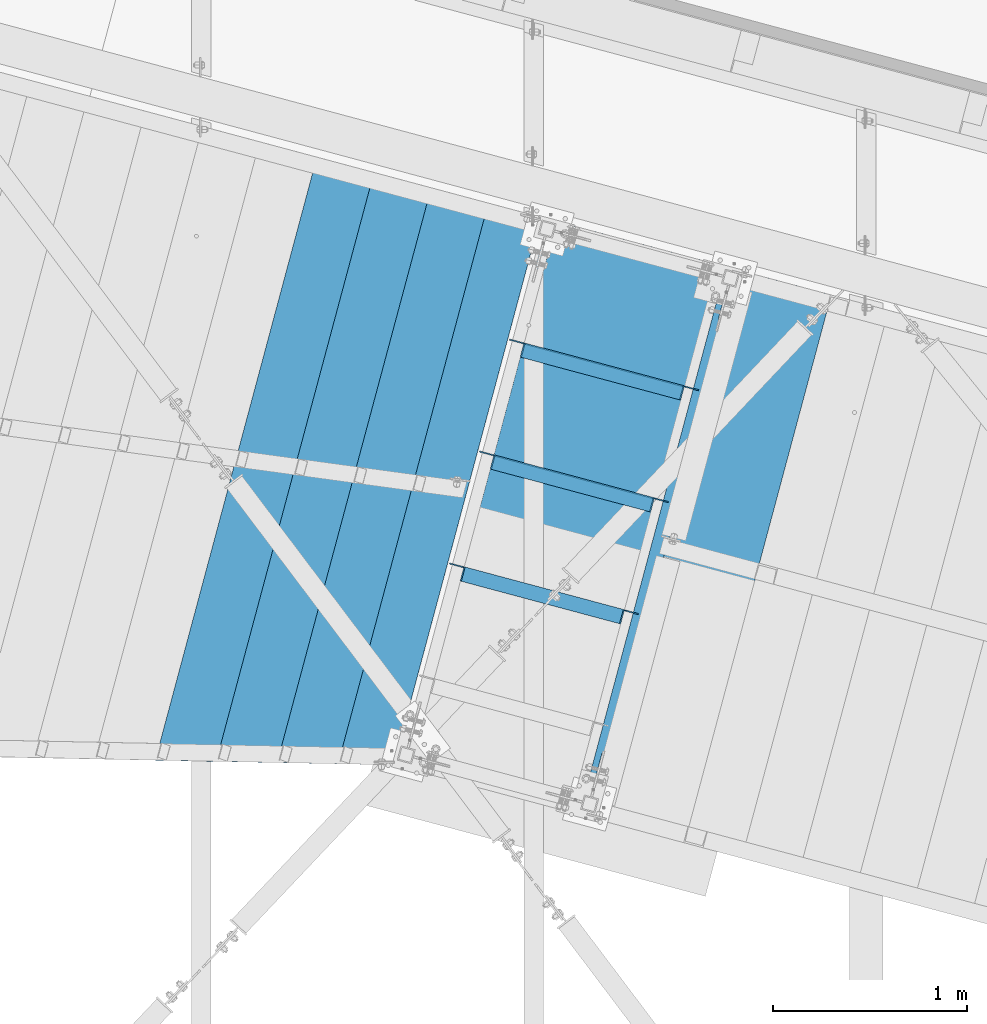
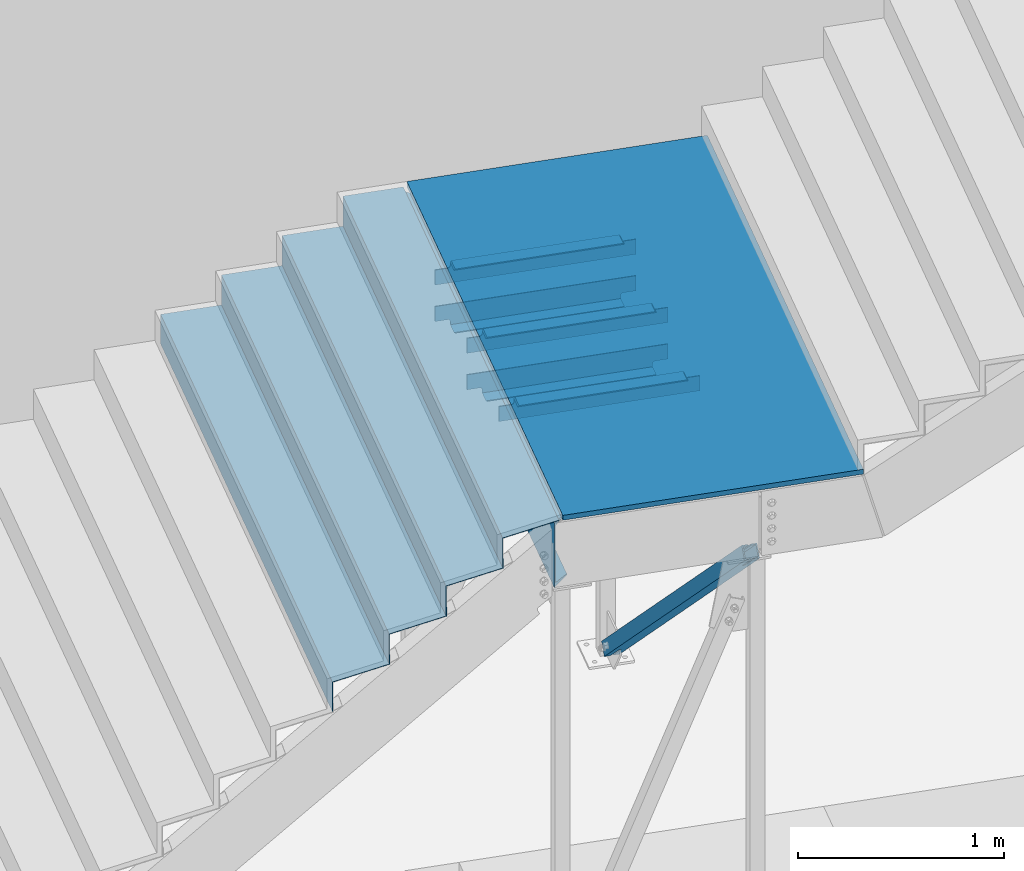
# One storey, part 1173 of 1763: 11 beams, 1 member, 4 elements without a shape of their own.
"""IFC2X3 building model written with IfcOpenShell, lengths in millimetres."""

import ifcopenshell
import ifcopenshell.guid

model = None  # the IFC model being written
_history = None  # IfcOwnerHistory: only IFC2X3 demands one
_inside = {}  # id of a spatial element -> (the spatial element, [elements in it])
_under = {}  # id of a project, library or spatial element -> (it, [spatial elements below it])
_declared = {}  # id of a project -> (the project, [libraries it declares])
_typed = {}  # id of a type object -> (the type object, [elements of that type])
_made_of = {}  # id of a material, layer set ... -> (it, [elements and type objects made of it])


def new_model(schema):
    """Start an empty IFC model of exactly this schema.

    Asked for "IFC4X3", IfcOpenShell would pick the latest addendum, in which some entities
    have other attributes; the version numbers below select the first issue.
    IFC2X3 requires an IfcOwnerHistory on every rooted entity: one is made here for all.
    """
    global model, _history
    if schema == "IFC4X3":
        model = ifcopenshell.file(schema_version=(4, 3, 0, 0))
    else:
        model = ifcopenshell.file(schema=schema)
    _inside.clear()
    _under.clear()
    _declared.clear()
    _typed.clear()
    _made_of.clear()
    _history = None
    if model.schema == "IFC2X3":
        org = make("IfcOrganization", Name="unknown")
        user = make(
            "IfcPersonAndOrganization",
            ThePerson=make("IfcPerson", FamilyName="unknown"),
            TheOrganization=org,
        )
        app = make(
            "IfcApplication",
            ApplicationDeveloper=org,
            Version="unknown",
            ApplicationFullName="unknown",
            ApplicationIdentifier="unknown",
        )
        _history = make(
            "IfcOwnerHistory",
            OwningUser=user,
            OwningApplication=app,
            ChangeAction="ADDED",
            CreationDate=0,
        )
    return model


def make(cls, **values):
    """One entity of the class cls with the attributes given. An attribute that is None is left unset."""
    return model.create_entity(
        cls, **{name: value for name, value in values.items() if value is not None}
    )


def rooted(cls, **values):
    """An entity with a GlobalId (a new one), such as an element, a storey or a relation."""
    return make(cls, GlobalId=ifcopenshell.guid.new(), OwnerHistory=_history, **values)


def si_unit(unit_type, name, prefix=None):
    """IfcSIUnit, for example si_unit("LENGTHUNIT", "METRE", prefix="MILLI")."""
    return make("IfcSIUnit", UnitType=unit_type, Prefix=prefix, Name=name)


def assignment(units):
    """IfcUnitAssignment: the units of a project."""
    return None if units is None else make("IfcUnitAssignment", Units=units)


def point(xyz):
    """IfcCartesianPoint."""
    return None if xyz is None else make("IfcCartesianPoint", Coordinates=xyz)


def direction(xyz):
    """IfcDirection."""
    return None if xyz is None else make("IfcDirection", DirectionRatios=xyz)


def frame(location, z_axis=None, x_axis=None):
    """IfcAxis2Placement3D, a coordinate frame: its origin and axes. An axis left out is left unset."""
    return make(
        "IfcAxis2Placement3D",
        Location=point(location),
        Axis=direction(z_axis),
        RefDirection=direction(x_axis),
    )


def origin_with_axes():
    """The frame at (0, 0, 0) with the z axis (0, 0, 1) and the x axis (1, 0, 0) written out."""
    return frame((0.0, 0.0, 0.0), z_axis=(0.0, 0.0, 1.0), x_axis=(1.0, 0.0, 0.0))


def place(relative_to, where):
    """IfcLocalPlacement: puts the frame where relative to a parent placement (None: the world)."""
    return make(
        "IfcLocalPlacement", PlacementRelTo=relative_to, RelativePlacement=where
    )


def context(
    kind, dimensions, precision=None, world=None, true_north=None, identifier=None
):
    """IfcGeometricRepresentationContext, for example the 3D "Model" context."""
    return make(
        "IfcGeometricRepresentationContext",
        ContextIdentifier=identifier,
        ContextType=kind,
        CoordinateSpaceDimension=dimensions,
        Precision=precision,
        WorldCoordinateSystem=world,
        TrueNorth=true_north,
    )


def subcontext(parent, identifier, kind, view, scale=None):
    """IfcGeometricRepresentationSubContext, for example "Body" below "Model"."""
    return make(
        "IfcGeometricRepresentationSubContext",
        ContextIdentifier=identifier,
        ContextType=kind,
        ParentContext=parent,
        TargetScale=scale,
        TargetView=view,
    )


def project(units=None, contexts=None):
    """IfcProject with its units and contexts."""
    return rooted(
        "IfcProject",
        Name="project",
        RepresentationContexts=contexts,
        UnitsInContext=assignment(units),
    )


def spatial(cls, under=None, at=None, **own):
    """A site, building, storey or space (cls), placed at a placement, below another one or the project."""
    s = rooted(cls, ObjectPlacement=at, **own)
    if under is not None:
        _under.setdefault(under.id(), (under, []))[1].append(s)
    return s


def faces_of(points, faces, orient=None, outer=None):
    """IfcFace entities. A face is a list of loops; a loop is a list of indices into points, from 0.

    orient and outer hold one flag for each loop. By default every Orientation is true, the
    first loop of a face is its IfcFaceOuterBound and the others are IfcFaceBound.
    """
    made = []
    for i, loops in enumerate(faces):
        bounds = []
        for j, loop in enumerate(loops):
            is_outer = j == 0 if outer is None else outer[i][j]
            bounds.append(
                make(
                    "IfcFaceOuterBound" if is_outer else "IfcFaceBound",
                    Bound=make("IfcPolyLoop", Polygon=[points[k] for k in loop]),
                    Orientation=True if orient is None else orient[i][j],
                )
            )
        made.append(make("IfcFace", Bounds=bounds))
    return made


def faceted_brep(points, faces, orient=None, outer=None, voids=None):
    """IfcFacetedBrep: a solid bounded by flat faces; with voids (closed shells), ...WithVoids."""
    shared = [point(p) for p in points]
    hull = make("IfcClosedShell", CfsFaces=faces_of(shared, faces, orient, outer))
    if voids is None:
        return make("IfcFacetedBrep", Outer=hull)
    return make(
        "IfcFacetedBrepWithVoids",
        Outer=hull,
        Voids=[
            make(cls, CfsFaces=faces_of(shared, fs, o, b)) for cls, fs, o, b in voids
        ],
    )


def shape(context_of_items, identifier, shape_type, items):
    """IfcShapeRepresentation: the items that make up one representation, for example the "Body"."""
    return make(
        "IfcShapeRepresentation",
        ContextOfItems=context_of_items,
        RepresentationIdentifier=identifier,
        RepresentationType=shape_type,
        Items=items,
    )


def material(Name=None, Category=None):
    """IfcMaterial."""
    return make("IfcMaterial", Name=Name, Category=Category)


def made_of(thing, what):
    """Note that an element or type object is made of a material, layer set ...; save() writes the relation."""
    if what is not None:
        _made_of.setdefault(what.id(), (what, []))[1].append(thing)
    return thing


def type_object(cls, material=None, **own):
    """A type object (cls), such as IfcWallType, which elements share."""
    return made_of(rooted(cls, **own), material)


def element(
    cls,
    number,
    at=None,
    inside=None,
    cuts=None,
    type_object=None,
    material=None,
    context=None,
    identifier="Body",
    shape_type=None,
    held_by="IfcProductDefinitionShape",
    body=None,
    shapes=None,
    **own,
):
    """One element of the class cls, such as IfcWall. Its Tag is "e" and its number.

    at: its placement. inside: the storey or other place that contains it. cuts: it is an
    opening in that element (IfcRelVoidsElement). A single representation is given by context,
    identifier, shape_type and body (its items); several are given by shapes. held_by: the class
    of the entity that holds the representations. save() writes the other relations.
    """
    e = rooted(cls, Tag="e%d" % number, ObjectPlacement=at, **own)
    if body is not None:
        shapes = [shape(context, identifier, shape_type, body)]
    if shapes is not None:
        e.Representation = make(held_by, Representations=shapes)
    if inside is not None:
        _inside.setdefault(inside.id(), (inside, []))[1].append(e)
    if cuts is not None:
        rooted(
            "IfcRelVoidsElement", RelatingBuildingElement=cuts, RelatedOpeningElement=e
        )
    if type_object is not None:
        _typed.setdefault(type_object.id(), (type_object, []))[1].append(e)
    return made_of(e, material)


def aggregate(whole, parts):
    """IfcRelAggregates: a whole, such as a stair, and the parts it consists of."""
    return rooted("IfcRelAggregates", RelatingObject=whole, RelatedObjects=parts)


def save(model, path):
    """Write the relations noted so far, then the file.

    IfcRelAggregates (storeys below a building ...), IfcRelContainedInSpatialStructure (elements
    in a storey), IfcRelDefinesByType, IfcRelAssociatesMaterial and IfcRelDeclares: one each for
    every whole, place, type object, material and project.
    """
    for whole, parts in _under.values():
        aggregate(whole, parts)
    for where, things in _inside.values():
        rooted(
            "IfcRelContainedInSpatialStructure",
            RelatedElements=things,
            RelatingStructure=where,
        )
    for kind, things in _typed.values():
        rooted("IfcRelDefinesByType", RelatedObjects=things, RelatingType=kind)
    for what, things in _made_of.values():
        rooted("IfcRelAssociatesMaterial", RelatedObjects=things, RelatingMaterial=what)
    for by, libraries in _declared.values():
        rooted("IfcRelDeclares", RelatingContext=by, RelatedDefinitions=libraries)
    model.write(path)


model = new_model("IFC2X3")

# Units and contexts
model_context = context("Model", 3, precision=1e-05, world=origin_with_axes())
body_context = subcontext(model_context, "Body", "Model", "MODEL_VIEW")
ifc_project = project(units=[si_unit("LENGTHUNIT", "METRE", prefix="MILLI"), si_unit("AREAUNIT", "SQUARE_METRE"), si_unit("VOLUMEUNIT", "CUBIC_METRE"), si_unit("MASSUNIT", "GRAM", prefix="KILO"), si_unit("TIMEUNIT", "SECOND"), si_unit("PLANEANGLEUNIT", "RADIAN"), si_unit("SOLIDANGLEUNIT", "STERADIAN"), si_unit("THERMODYNAMICTEMPERATUREUNIT", "DEGREE_CELSIUS"), si_unit("LUMINOUSINTENSITYUNIT", "LUMEN")], contexts=[model_context])

# Site, building, storey
site_placement = place(None, origin_with_axes())
site = spatial("IfcSite", under=ifc_project, at=site_placement, CompositionType="ELEMENT")
building_placement = place(site_placement, origin_with_axes())
building = spatial("IfcBuilding", under=site, at=building_placement, Name="Undefined", CompositionType="ELEMENT")
storey_placement = place(building_placement, origin_with_axes())
storey = spatial("IfcBuildingStorey", under=building, at=storey_placement, Name="Undefined", CompositionType="ELEMENT", Elevation=0.0)

# Assembly, beams
assembly_1_placement = place(storey_placement, origin_with_axes())
assembly_1 = element("IfcElementAssembly", 1, at=assembly_1_placement, inside=storey, Name="FRAME", AssemblyPlace="NOTDEFINED", PredefinedType="RIGID_FRAME")
ifc_material_1 = material(Name="STEEL/A36")
beam_type_1 = type_object("IfcBeamType", Name="L5X3X1/4", PredefinedType="NOTDEFINED")
beam_1_placement = place(assembly_1_placement, frame((-27148.6271990077, 61232.1170575951, 2565.40000004752), z_axis=(0.0, 0.0, -1.0), x_axis=(-0.965913267114846, 0.258865912030774, 0.0)))
beam_1 = element("IfcBeam", 2, at=beam_1_placement, type_object=beam_type_1, material=ifc_material_1, Name="ANGLE", ObjectType="L5X3X1/4", context=body_context, shape_type="Brep", body=[
    faceted_brep([(85.7250002993387, -38.0999999998603, -57.1500000000001), (92.0750017297105, -38.0999999998603, -63.499999957723), (935.037468048155, -38.0999999993292, -63.4999999958368), (941.387469479872, -38.0999999993292, -57.1500001000077), (85.7250005197857, 31.7499999999927, -57.1500000000001), (941.387469631416, 31.7500000005239, -57.1500000000001), (73.0250001453314, 31.7499999999854, -25.4000020452313), (73.0250001653767, 38.0999999999694, -25.4000020452313), (77.8850798569911, 38.0999999999767, -26.3667318056164), (77.8850798369385, 31.7499999999854, -26.3667318056164), (82.005256516939, 38.0999999999694, -29.1197456684899), (82.0052564968937, 31.7499999999782, -29.1197456684899), (84.7582705631648, 38.0999999999694, -33.2399222059203), (84.7582705431123, 31.7499999999854, -33.2399222059203), (85.7250005398237, 38.0999999999694, -38.1000018544964), (85.7250005197711, 31.7499999999927, -38.1000018544964), (85.7250005398237, 38.0999999999694, -57.1500000397209), (92.0750019702682, 38.099999999984, -63.5), (935.037468215283, 38.1000000005079, -63.5), (941.387469645473, 38.1000000005079, -57.1500001197246), (941.387469645473, 38.1000000005079, -38.1000019147832), (941.387469631547, 31.7500000005239, -38.1000019147832), (942.354199622132, 38.1000000005151, -33.239922266207), (942.354199608213, 31.7500000005239, -33.239922266207), (945.107213668365, 38.1000000005079, -29.1197457287767), (945.107213654439, 31.7500000005239, -29.1197457287767), (949.22739032832, 38.1000000005151, -26.3667318659031), (949.227390314394, 31.7500000005311, -26.3667318659031), (954.087470019935, 38.1000000005224, -25.4000021055181), (954.087470006009, 31.7500000005311, -25.4000021055181), (1017.58746721857, 38.1000000005588, -25.400004931219), (1017.58746719851, 31.7500000005748, -25.4000049312194), (1017.58746721857, 38.1000000005588, 63.5), (1017.58746719851, 31.7500000005748, 63.5), (9.52500204597163, 31.7499999999345, 63.5), (9.52500204597163, 31.7499999999345, -25.4000048709327), (9.52500206602417, 38.0999999999258, -25.4000048709327), (9.52500206602417, 38.0999999999258, 63.5)], [[[0, 1, 2, 3]], [[4, 0, 3, 5]], [[6, 7, 8, 9]], [[9, 8, 10, 11]], [[11, 10, 12, 13]], [[13, 12, 14, 15]], [[15, 14, 16, 4]], [[1, 0, 4, 16, 17]], [[1, 17, 18, 2]], [[3, 2, 18, 19, 5]], [[20, 21, 5, 19]], [[21, 20, 22, 23]], [[23, 22, 24, 25]], [[25, 24, 26, 27]], [[27, 26, 28, 29]], [[29, 28, 30, 31]], [[30, 32, 33, 31]], [[34, 35, 6, 9, 11, 13, 15, 4, 5, 21, 23, 25, 27, 29, 31, 33]], [[7, 6, 35, 36]], [[28, 26, 24, 22, 20, 19, 18, 17, 16, 14, 12, 10, 8, 7, 36, 37, 32, 30]], [[37, 34, 33, 32]], [[36, 35, 34, 37]]]),
])
beam_2_placement = place(assembly_1_placement, frame((-27986.2117074256, 62074.555092622, 2311.40000006723), z_axis=(0.0, 0.0, 1.0), x_axis=(0.965913267114843, -0.258865912030785, 0.0)))
beam_2 = element("IfcBeam", 3, at=beam_2_placement, type_object=beam_type_1, material=ifc_material_1, Name="ANGLE", ObjectType="L5X3X1/4", context=body_context, shape_type="Brep", body=[
    faceted_brep([(85.7250002993387, -38.0999999998603, -57.1500000000001), (92.0750017297105, -38.0999999998603, -63.499999957723), (935.037468048155, -38.0999999993292, -63.4999999958368), (941.387469479872, -38.0999999993292, -57.1500001000077), (92.0750019702682, 38.099999999984, -63.5), (935.037468215283, 38.1000000005079, -63.5), (949.227390314394, 31.7500000005311, -26.3667318659031), (949.22739032832, 38.1000000005151, -26.3667318659031), (954.087470019935, 38.1000000005224, -25.4000021055181), (954.087470006009, 31.7500000005311, -25.4000021055181), (945.107213654439, 31.7500000005239, -29.1197457287767), (945.107213668365, 38.1000000005079, -29.1197457287767), (942.354199608213, 31.7500000005239, -33.239922266207), (942.354199622132, 38.1000000005151, -33.239922266207), (941.387469631547, 31.7500000005239, -38.1000019147832), (941.387469645473, 38.1000000005079, -38.1000019147832), (941.387469631416, 31.7500000005239, -57.1500000000001), (941.387469645473, 38.1000000005079, -57.1500001197246), (85.7250005197857, 31.7499999999927, -57.1500000000001), (85.7250005398237, 38.0999999999694, -57.1500000397209), (85.7250005197711, 31.7499999999927, -38.1000018544964), (85.7250005398237, 38.0999999999694, -38.1000018544964), (84.7582705431123, 31.7499999999854, -33.2399222059203), (84.7582705631648, 38.0999999999694, -33.2399222059203), (82.0052564968937, 31.7499999999782, -29.1197456684899), (82.005256516939, 38.0999999999694, -29.1197456684899), (77.8850798369385, 31.7499999999854, -26.3667318056164), (77.8850798569911, 38.0999999999767, -26.3667318056164), (73.0250001453314, 31.7499999999854, -25.4000020452313), (73.0250001653767, 38.0999999999694, -25.4000020452313), (9.52500204597163, 31.7499999999345, -25.4000048709327), (9.52500206602417, 38.0999999999258, -25.4000048709327), (9.52500204597163, 31.7499999999345, 63.5), (9.52500206602417, 38.0999999999258, 63.5), (1017.58746719851, 31.7500000005748, 63.5), (1017.58746721857, 38.1000000005588, 63.5), (1017.58746721857, 38.1000000005588, -25.400004931219), (1017.58746719851, 31.7500000005748, -25.4000049312194)], [[[0, 1, 2, 3]], [[1, 4, 5, 2]], [[6, 7, 8, 9]], [[10, 11, 7, 6]], [[12, 13, 11, 10]], [[14, 15, 13, 12]], [[15, 14, 16, 17]], [[3, 2, 5, 17, 16]], [[18, 0, 3, 16]], [[1, 0, 18, 19, 4]], [[20, 21, 19, 18]], [[22, 23, 21, 20]], [[24, 25, 23, 22]], [[26, 27, 25, 24]], [[28, 29, 27, 26]], [[29, 28, 30, 31]], [[31, 30, 32, 33]], [[33, 32, 34, 35]], [[8, 7, 11, 13, 15, 17, 5, 4, 19, 21, 23, 25, 27, 29, 31, 33, 35, 36]], [[9, 8, 36, 37]], [[32, 30, 28, 26, 24, 22, 20, 18, 16, 14, 12, 10, 6, 9, 37, 34]], [[36, 35, 34, 37]]]),
])
beam_3_placement = place(assembly_1_placement, frame((-26994.1101361108, 61808.6706867366, 2565.40000003567), z_axis=(0.0, 0.0, -1.0), x_axis=(-0.965913267114846, 0.258865912030774, 0.0)))
beam_3 = element("IfcBeam", 4, at=beam_3_placement, type_object=beam_type_1, material=ifc_material_1, Name="ANGLE", ObjectType="L5X3X1/4", context=body_context, shape_type="Brep", body=[
    faceted_brep([(73.0250001653767, 38.0999999999694, -25.4000020452313), (73.0250001453314, 31.7499999999854, -25.4000020452313), (9.52494874069089, 31.7499999999272, -25.4000049337974), (9.52494904255582, 38.0999999999112, -25.4000049337974), (77.8850798569911, 38.0999999999767, -26.3667318056164), (77.8850798369385, 31.7499999999854, -26.3667318056164), (82.005256516939, 38.0999999999694, -29.1197456684899), (82.0052564968937, 31.7499999999782, -29.1197456684899), (84.7582705631648, 38.0999999999694, -33.2399222059203), (84.7582705431123, 31.7499999999854, -33.2399222059203), (85.7250005398237, 38.0999999999694, -38.1000018544964), (85.7250005197711, 31.7499999999927, -38.1000018544964), (85.7250005398237, 38.0999999999694, -57.1500000397209), (85.7250005197857, 31.7499999999927, -57.1500000000001), (85.7250002993387, -38.0999999998603, -57.1500000000001), (941.387469479872, -38.0999999993292, -57.1500001000077), (941.387469631416, 31.7500000005239, -57.1500000000001), (92.0750017297105, -38.0999999998603, -63.499999957723), (92.0750019702682, 38.099999999984, -63.5), (935.037468215283, 38.1000000005079, -63.5), (935.037468048155, -38.0999999993292, -63.4999999958368), (941.387469645473, 38.1000000005079, -57.1500001197246), (941.387469645473, 38.1000000005079, -38.1000019147832), (941.387469631547, 31.7500000005239, -38.1000019147832), (942.354199622132, 38.1000000005151, -33.239922266207), (942.354199608213, 31.7500000005239, -33.239922266207), (945.107213668365, 38.1000000005079, -29.1197457287767), (945.107213654439, 31.7500000005239, -29.1197457287767), (949.22739032832, 38.1000000005151, -26.3667318659031), (949.227390314394, 31.7500000005311, -26.3667318659031), (954.087470019935, 38.1000000005224, -25.4000021055181), (954.087470006009, 31.7500000005311, -25.4000021055181), (1017.58746721857, 38.1000000005588, -25.400004931219), (1017.58746719851, 31.7500000005748, -25.4000049312194), (1017.58746719851, 31.7500000005748, 63.5), (9.52494874069089, 31.7499999999272, 63.5), (1017.58746721857, 38.1000000005588, 63.5), (9.52494904255582, 38.0999999999112, 63.5)], [[[0, 1, 2, 3]], [[1, 0, 4, 5]], [[5, 4, 6, 7]], [[7, 6, 8, 9]], [[9, 8, 10, 11]], [[11, 10, 12, 13]], [[13, 14, 15, 16]], [[17, 18, 19, 20]], [[15, 20, 19, 21, 16]], [[22, 23, 16, 21]], [[23, 22, 24, 25]], [[25, 24, 26, 27]], [[27, 26, 28, 29]], [[29, 28, 30, 31]], [[31, 30, 32, 33]], [[1, 5, 7, 9, 11, 13, 16, 23, 25, 27, 29, 31, 33, 34, 35, 2]], [[32, 36, 34, 33]], [[34, 36, 37, 35]], [[3, 2, 35, 37]], [[36, 32, 30, 28, 26, 24, 22, 21, 19, 18, 12, 10, 8, 6, 4, 0, 3, 37]], [[17, 14, 13, 12, 18]], [[14, 17, 20, 15]]]),
])
beam_4_placement = place(assembly_1_placement, frame((-27831.6946445281, 62651.1087217658, 2311.4000000554), z_axis=(0.0, 0.0, 1.0), x_axis=(0.965913267114843, -0.258865912030785, 0.0)))
beam_4 = element("IfcBeam", 5, at=beam_4_placement, type_object=beam_type_1, material=ifc_material_1, Name="ANGLE", ObjectType="L5X3X1/4", context=body_context, shape_type="Brep", body=[
    faceted_brep([(85.7250002993387, -38.0999999998603, -57.1500000000001), (92.0750017297105, -38.0999999998603, -63.499999957723), (935.037468048155, -38.0999999993292, -63.4999999958368), (941.387469479872, -38.0999999993292, -57.1500001000077), (92.0750019702682, 38.099999999984, -63.5), (935.037468215283, 38.1000000005079, -63.5), (949.227390314394, 31.7500000005311, -26.3667318659031), (949.22739032832, 38.1000000005151, -26.3667318659031), (954.087470019935, 38.1000000005224, -25.4000021055181), (954.087470006009, 31.7500000005311, -25.4000021055181), (945.107213654439, 31.7500000005239, -29.1197457287767), (945.107213668365, 38.1000000005079, -29.1197457287767), (942.354199608213, 31.7500000005239, -33.239922266207), (942.354199622132, 38.1000000005151, -33.239922266207), (941.387469631547, 31.7500000005239, -38.1000019147832), (941.387469645473, 38.1000000005079, -38.1000019147832), (941.387469631416, 31.7500000005239, -57.1500000000001), (941.387469645473, 38.1000000005079, -57.1500001197246), (85.7250005197857, 31.7499999999927, -57.1500000000001), (85.7250005398237, 38.0999999999694, -57.1500000397209), (85.7250005197711, 31.7499999999927, -38.1000018544964), (85.7250005398237, 38.0999999999694, -38.1000018544964), (84.7582705431123, 31.7499999999854, -33.2399222059203), (84.7582705631648, 38.0999999999694, -33.2399222059203), (82.0052564968937, 31.7499999999782, -29.1197456684899), (82.005256516939, 38.0999999999694, -29.1197456684899), (77.8850798369385, 31.7499999999854, -26.3667318056164), (77.8850798569911, 38.0999999999767, -26.3667318056164), (73.0250001453314, 31.7499999999854, -25.4000020452313), (73.0250001653767, 38.0999999999694, -25.4000020452313), (9.52500204597163, 31.7499999999345, -25.4000048709327), (9.52500206602417, 38.0999999999258, -25.4000048709327), (9.52500204597163, 31.7499999999345, 63.5), (9.52500206602417, 38.0999999999258, 63.5), (1017.58746719851, 31.7500000005748, 63.5), (1017.58746721857, 38.1000000005588, 63.5), (1017.58746721857, 38.1000000005588, -25.400004931219), (1017.58746719851, 31.7500000005748, -25.4000049312194)], [[[0, 1, 2, 3]], [[1, 4, 5, 2]], [[6, 7, 8, 9]], [[10, 11, 7, 6]], [[12, 13, 11, 10]], [[14, 15, 13, 12]], [[15, 14, 16, 17]], [[3, 2, 5, 17, 16]], [[18, 0, 3, 16]], [[1, 0, 18, 19, 4]], [[20, 21, 19, 18]], [[22, 23, 21, 20]], [[24, 25, 23, 22]], [[26, 27, 25, 24]], [[28, 29, 27, 26]], [[29, 28, 30, 31]], [[31, 30, 32, 33]], [[33, 32, 34, 35]], [[8, 7, 11, 13, 15, 17, 5, 4, 19, 21, 23, 25, 27, 29, 31, 33, 35, 36]], [[9, 8, 36, 37]], [[32, 30, 28, 26, 24, 22, 20, 18, 16, 14, 12, 10, 6, 9, 37, 34]], [[36, 35, 34, 37]]]),
])
beam_5_placement = place(assembly_1_placement, frame((-26839.5930732139, 62385.2243158781, 2565.40000002384), z_axis=(0.0, 0.0, -1.0), x_axis=(-0.965913267114846, 0.258865912030774, 0.0)))
beam_5 = element("IfcBeam", 6, at=beam_5_placement, type_object=beam_type_1, material=ifc_material_1, Name="ANGLE", ObjectType="L5X3X1/4", context=body_context, shape_type="Brep", body=[
    faceted_brep([(85.7250002993387, -38.0999999998603, -57.1500000000001), (92.0750017297105, -38.0999999998603, -63.499999957723), (935.037468048155, -38.0999999993292, -63.4999999958368), (941.387469479872, -38.0999999993292, -57.1500001000077), (85.7250005197857, 31.7499999999927, -57.1500000000001), (941.387469631416, 31.7500000005239, -57.1500000000001), (73.0250001453314, 31.7499999999854, -25.4000020452313), (73.0250001653767, 38.0999999999694, -25.4000020452313), (77.8850798569911, 38.0999999999767, -26.3667318056164), (77.8850798369385, 31.7499999999854, -26.3667318056164), (82.005256516939, 38.0999999999694, -29.1197456684899), (82.0052564968937, 31.7499999999782, -29.1197456684899), (84.7582705631648, 38.0999999999694, -33.2399222059203), (84.7582705431123, 31.7499999999854, -33.2399222059203), (85.7250005398237, 38.0999999999694, -38.1000018544964), (85.7250005197711, 31.7499999999927, -38.1000018544964), (85.7250005398237, 38.0999999999694, -57.1500000397209), (92.0750019702682, 38.099999999984, -63.5), (935.037468215283, 38.1000000005079, -63.5), (941.387469645473, 38.1000000005079, -57.1500001197246), (941.387469645473, 38.1000000005079, -38.1000019147832), (941.387469631547, 31.7500000005239, -38.1000019147832), (942.354199622132, 38.1000000005151, -33.239922266207), (942.354199608213, 31.7500000005239, -33.239922266207), (945.107213668365, 38.1000000005079, -29.1197457287767), (945.107213654439, 31.7500000005239, -29.1197457287767), (949.22739032832, 38.1000000005151, -26.3667318659031), (949.227390314394, 31.7500000005311, -26.3667318659031), (954.087470019935, 38.1000000005224, -25.4000021055181), (954.087470006009, 31.7500000005311, -25.4000021055181), (1017.58746721857, 38.1000000005588, -25.400004931219), (1017.58746719851, 31.7500000005748, -25.4000049312194), (1017.58746721857, 38.1000000005588, 63.5), (1017.58746719851, 31.7500000005748, 63.5), (9.52500204597163, 31.7499999999345, 63.5), (9.52500204597163, 31.7499999999345, -25.4000048709327), (9.52500206602417, 38.0999999999258, -25.4000048709327), (9.52500206602417, 38.0999999999258, 63.5)], [[[0, 1, 2, 3]], [[4, 0, 3, 5]], [[6, 7, 8, 9]], [[9, 8, 10, 11]], [[11, 10, 12, 13]], [[13, 12, 14, 15]], [[15, 14, 16, 4]], [[1, 0, 4, 16, 17]], [[1, 17, 18, 2]], [[3, 2, 18, 19, 5]], [[20, 21, 5, 19]], [[21, 20, 22, 23]], [[23, 22, 24, 25]], [[25, 24, 26, 27]], [[27, 26, 28, 29]], [[29, 28, 30, 31]], [[30, 32, 33, 31]], [[34, 35, 6, 9, 11, 13, 15, 4, 5, 21, 23, 25, 27, 29, 31, 33]], [[7, 6, 35, 36]], [[28, 26, 24, 22, 20, 19, 18, 17, 16, 14, 12, 10, 8, 7, 36, 37, 32, 30]], [[37, 34, 33, 32]], [[36, 35, 34, 37]]]),
])
beam_type_2 = type_object("IfcBeamType", Name="C15X33.9", PredefinedType="NOTDEFINED")
beam_6_placement = place(assembly_1_placement, frame((-27625.913364713, 63253.3680132707, 2438.40000007105), z_axis=(0.0, 0.0, -1.0), x_axis=(-0.258865912030778, -0.965913267114844, 3.00823476209188e-08)))
beam_6 = element("IfcBeam", 7, at=beam_6_placement, type_object=beam_type_2, material=ifc_material_1, Name="FRAME", ObjectType="C15X33.9", context=body_context, shape_type="Brep", body=[
    faceted_brep([(-50.5436514046814, 42.8624999999665, -190.5), (-50.5436514046814, 42.8624999999665, 190.5), (2870.4656608373, 42.8625000017928, 190.5), (2870.4656608373, 42.8625000017928, -190.5), (35.1813485384482, -42.8624999999738, 190.5), (2784.74066078044, -42.8624999982567, 190.5), (35.1813485384482, -42.8624999999738, 181.7658925), (2784.74066078044, -42.8624999982567, 181.7658925), (-41.0186514109955, 33.3374999999724, 169.0709725), (2860.94066083099, 33.3375000017913, 169.0709725), (-41.0186514109955, 33.3374999999724, -169.0709725), (2860.94066083099, 33.3375000017913, -169.0709725), (35.1813485384482, -42.8624999999738, -181.7658925), (2784.74066078044, -42.8624999982567, -181.7658925), (35.1813485384482, -42.8624999999738, -190.5), (2784.74066078044, -42.8624999982567, -190.5)], [[[0, 1, 2, 3]], [[1, 4, 5, 2]], [[4, 6, 7, 5]], [[6, 8, 9, 7]], [[8, 10, 11, 9]], [[10, 12, 13, 11]], [[12, 14, 15, 13]], [[14, 0, 3, 15]], [[5, 7, 9, 11, 13, 15, 3, 2]], [[14, 12, 10, 8, 6, 4, 1, 0]]]),
])
aggregate(assembly_1, [beam_1, beam_2, beam_3, beam_4, beam_5, beam_6])

# Assembly, member
assembly_2_placement = place(storey_placement, origin_with_axes())
assembly_2 = element("IfcElementAssembly", 8, at=assembly_2_placement, inside=storey, Name="BRACE", AssemblyPlace="NOTDEFINED", PredefinedType="RIGID_FRAME")
ifc_material_2 = material()
member_type = type_object("IfcMemberType", Name="HSS3X3X1/4", PredefinedType="NOTDEFINED")
member_placement = place(assembly_2_placement, frame((-26675.2573715718, 62998.3060575739, -254.000000011894), z_axis=(0.172357044040262, 0.643130363150223, 0.746107489148826), x_axis=(-0.193141324899824, -0.720675248626209, 0.66582551365466)))
member = element("IfcMember", 9, at=member_placement, type_object=member_type, material=ifc_material_2, Name="BRACE", ObjectType="HSS3X3X1/4", context=body_context, shape_type="Brep", body=[
    faceted_brep([(3638.48220902156, 6.35008143950108, 38.1000000057029), (3432.10720324847, 6.35008143055893, 38.1000000053682), (3432.10720324846, 6.35006785712176, 31.7500000053842), (3638.48220902335, 6.35006786607119, 31.7500000057044), (3429.6771634895, 5.86671646917239, 38.1000000053682), (3429.6771634895, 5.86670289573522, 31.7500000053769), (3427.61707525551, 4.4902095188736, 38.1000000053609), (3427.6170752555, 4.49019594542915, 31.7500000053769), (3426.24056830536, 2.43012128476403, 38.1000000053682), (3426.24056830535, 2.43010771133413, 31.7500000053769), (3425.75720334413, 8.15303792478517e-05, 38.1000000053755), (3425.75720334412, 6.79569493513554e-05, 31.7500000053842), (3426.24056830547, -2.42995822864759, 38.1000000053755), (3426.24056830547, -2.42997180208476, 31.7500000053842), (3427.61707525574, -4.49004646270623, 38.1000000053755), (3427.61707525574, -4.4900600361434, 31.7500000053842), (3429.67716348985, -5.86655341291771, 38.1000000053828), (3429.67716348984, -5.86656698634761, 31.7500000053915), (3432.10720324887, -6.34991837415146, 38.1000000053828), (3432.10720324886, -6.34993194758863, 31.7500000053988), (3638.48220902184, -6.34991836978588, 38.1000000057174), (3638.48220902363, -6.34993194323033, 31.7500000057262), (3638.48220904131, 6.34993213165581, -31.7499999941647), (3432.10720324836, 6.34993212277186, -31.7499999944848), (3432.10720324835, 6.34991854934196, -38.0999999944761), (3638.4822090431, 6.34991855821863, -38.0999999941487), (3429.67716348941, 5.86656716138532, -31.7499999944921), (3429.6771634894, 5.86655358795542, -38.0999999944834), (3427.61707525542, 4.49006021108653, -31.7499999944994), (3427.61707525541, 4.49004663764936, -38.0999999944834), (3426.24056830526, 2.42997197698423, -31.7499999944921), (3426.24056830525, 2.42995840354706, -38.0999999944761), (3425.75720334403, -6.77774078212678e-05, -31.7499999944921), (3425.75720334402, -8.13508377177641e-05, -38.0999999944761), (3426.24056830537, -2.43010753643466, -31.7499999944921), (3426.24056830536, -2.43012110986456, -38.0999999944761), (3427.61707525566, -4.4901957704933, -31.7499999944848), (3427.61707525564, -4.49020934393047, -38.0999999944688), (3429.67716348975, -5.86670272070478, -31.7499999944848), (3429.67716348973, -5.86671629413468, -38.0999999944688), (3432.10720324878, -6.35006768193853, -31.7499999944775), (3432.10720324876, -6.3500812553757, -38.0999999944615), (3638.48220904159, -6.35006767763116, -31.7499999941501), (3638.48220904338, -6.35008125106833, -38.0999999941341), (119.108855174149, 31.7499999999636, 31.7500000001019), (119.108855184961, 31.7499999998763, -31.7499999997817), (3638.48220904074, 31.7499999956926, -31.7499999941938), (3638.48220902279, 31.7499999957799, 31.7500000056825), (3638.4822090242, -31.7500000043583, 31.750000005748), (119.108855140694, -31.7500000001746, 31.7500000001673), (119.108855154074, -6.3498838334126, 31.7500000001382), (325.483862301953, -6.34992280274309, 31.7500000004729), (327.913902429478, -5.86655818548752, 31.7500000004729), (329.973991070605, -4.49005131470039, 31.7500000004729), (331.350498329979, -2.42996293320175, 31.7500000004657), (331.83386340562, 7.71031627664343e-05, 31.7500000004657), (331.350498557724, 2.4301169274986, 31.7500000004657), (329.973991914048, 4.49020501541236, 31.7500000004657), (327.913904083645, 5.86671204445884, 31.7500000004511), (325.483864690068, 6.35007734692044, 31.7500000004584), (119.108855160775, 6.35011599087738, 31.7500000001237), (119.108855151506, -31.7500000002619, -31.749999999709), (3638.48220904215, -31.7500000044456, -31.749999994121), (119.10885517158, 6.34999456460355, -31.7499999997526), (325.483864689799, 6.34995592047926, -31.7499999994252), (327.913904083376, 5.86659061803221, -31.7499999994252), (329.973991913779, 4.49008358897845, -31.7499999994179), (331.350498557462, 2.4299955010647, -31.7499999994179), (331.833863405351, -4.43232638644986e-05, -31.7499999994106), (331.35049832971, -2.43008435963566, -31.7499999994034), (329.973991070343, -4.4901727411343, -31.7499999994106), (327.913902429209, -5.86667961191415, -31.7499999994106), (325.483862301684, -6.350044229177, -31.7499999994179), (119.108855164894, -6.35000525968644, -31.7499999997453), (119.108855172657, 6.34998242196889, -38.0999999997439), (325.48386468977, 6.34994377783005, -38.0999999994165), (327.913904083354, 5.86657847538299, -38.0999999994092), (329.97399191375, 4.49007144632924, -38.0999999994019), (331.350498557433, 2.42998335842276, -38.0999999994019), (331.833863405322, -5.64659130759537e-05, -38.0999999993946), (331.350498329681, -2.43009650227759, -38.0999999994019), (329.973991070314, -4.49018488377624, -38.0999999993946), (327.913902429187, -5.86669175456336, -38.0999999993946), (325.483862301662, -6.35005637181894, -38.0999999994019), (119.10885516597, -6.35001740231382, -38.0999999997293), (119.10885514925, -38.1000000002823, -38.099999999693), (119.10885513627, -38.1000000001804, 38.1000000001586), (119.108855152997, -6.34987169077795, 38.1000000001222), (325.483862301982, -6.34991066010116, 38.1000000004497), (327.913902429507, -5.86654604283831, 38.1000000004497), (329.973991070634, -4.49003917205846, 38.1000000004569), (331.350498330001, -2.42995079055981, 38.1000000004497), (331.833863405642, 8.92458119778894e-05, 38.1000000004569), (331.350498557753, 2.43012907014781, 38.1000000004569), (329.973991914077, 4.49021715805429, 38.1000000004497), (327.913904083674, 5.86672418710077, 38.1000000004424), (325.483864690097, 6.3500894895551, 38.1000000004351), (119.108855159691, 6.35012813350477, 38.100000000115), (119.108855176411, 38.099999999984, 38.1000000000713), (119.108855189384, 38.0999999998821, -38.099999999773), (3638.48220902086, 38.0999999958076, 38.1000000056665), (3638.48220904241, 38.0999999956985, -38.0999999941923), (3638.48220904408, -38.100000004466, -38.0999999940977), (3638.48220902254, -38.1000000043641, 38.1000000057538)], [[[0, 1, 2, 3]], [[4, 5, 2, 1]], [[6, 7, 5, 4]], [[8, 9, 7, 6]], [[10, 11, 9, 8]], [[12, 13, 11, 10]], [[14, 15, 13, 12]], [[16, 17, 15, 14]], [[18, 19, 17, 16]], [[20, 21, 19, 18]], [[22, 23, 24, 25]], [[26, 27, 24, 23]], [[28, 29, 27, 26]], [[30, 31, 29, 28]], [[32, 33, 31, 30]], [[34, 35, 33, 32]], [[36, 37, 35, 34]], [[38, 39, 37, 36]], [[40, 41, 39, 38]], [[42, 43, 41, 40]], [[44, 45, 46, 47]], [[48, 49, 50, 51, 52, 53, 54, 55, 56, 57, 58, 59, 60, 44, 47, 3, 2, 5, 7, 9, 11, 13, 15, 17, 19, 21]], [[61, 49, 48, 62]], [[38, 36, 34, 32, 30, 28, 26, 23, 22, 46, 45, 63, 64, 65, 66, 67, 68, 69, 70, 71, 72, 73, 61, 62, 42, 40]], [[63, 74, 75, 64]], [[64, 75, 76, 65]], [[65, 76, 77, 66]], [[66, 77, 78, 67]], [[67, 78, 79, 68]], [[68, 79, 80, 69]], [[69, 80, 81, 70]], [[70, 81, 82, 71]], [[71, 82, 83, 72]], [[72, 83, 84, 73]], [[49, 61, 73, 84, 85, 86, 87, 50]], [[88, 51, 50, 87]], [[89, 52, 51, 88]], [[90, 53, 52, 89]], [[91, 54, 53, 90]], [[92, 55, 54, 91]], [[93, 56, 55, 92]], [[94, 57, 56, 93]], [[95, 58, 57, 94]], [[96, 59, 58, 95]], [[97, 60, 59, 96]], [[98, 99, 74, 63, 45, 44, 60, 97]], [[99, 98, 100, 101]], [[47, 46, 22, 25, 101, 100, 0, 3]], [[102, 85, 84, 83, 82, 81, 80, 79, 78, 77, 76, 75, 74, 99, 101, 25, 24, 27, 29, 31, 33, 35, 37, 39, 41, 43]], [[86, 85, 102, 103]], [[16, 14, 12, 10, 8, 6, 4, 1, 0, 100, 98, 97, 96, 95, 94, 93, 92, 91, 90, 89, 88, 87, 86, 103, 20, 18]], [[103, 102, 43, 42, 62, 48, 21, 20]]]),
])
aggregate(assembly_2, [member])

# Assembly, beams
assembly_3_placement = place(storey_placement, origin_with_axes())
assembly_3 = element("IfcElementAssembly", 10, at=assembly_3_placement, inside=storey, Name="STRINGER", AssemblyPlace="NOTDEFINED", PredefinedType="RIGID_FRAME")
beam_type_3 = type_object("IfcBeamType", PredefinedType="NOTDEFINED")
beam_7_placement = place(assembly_3_placement, frame((-28314.8001668294, 61903.4973001772, 2508.24999770467), z_axis=(-0.258865912030778, -0.965913267114844, 3.00823476209188e-08), x_axis=(0.0, 0.0, -1.0)))
beam_7 = element("IfcBeam", 11, at=beam_7_placement, type_object=beam_type_3, material=ifc_material_1, Name="BENT_PLATE", context=body_context, shape_type="Brep", body=[
    faceted_brep([(47.6250004941908, -309.562503402536, -1532.73099999938), (47.6250004277899, -1.58749998997519, -1532.73099999979), (1.98906491277739e-09, -1.58750000096916, -1532.73099999993), (1.25783117255196e-09, 1.58749999903375, -1532.73099999993), (50.8000004270943, 1.5875000107626, -1532.73099999978), (50.8000004934947, -306.387503401842, -1532.73099999938), (222.25000006546, -306.387503363985, -1532.73099999889), (222.250000066159, -309.562503363988, -1532.73099999889), (222.250000062982, -309.562503359972, 1532.2217430511), (47.6250004911003, -309.562503398505, 1532.22174830391), (47.6250004226108, -1.58749998810526, 1455.989425042), (-1.17825038614683e-09, -1.58749999909924, 1455.98942647471), (-1.90857463167049e-09, 1.58750000090367, 1455.2035262436), (50.8000004219161, 1.58750001262524, 1455.20352471538), (50.8000004904052, -306.387503397811, 1531.43584797729), (222.250000062284, -306.387503359976, 1531.43584281998)], [[[0, 1, 2, 3, 4, 5, 6, 7]], [[0, 7, 8, 9]], [[1, 0, 9, 10]], [[2, 1, 10, 11]], [[3, 2, 11, 12]], [[4, 3, 12, 13]], [[5, 4, 13, 14]], [[6, 5, 14, 15]], [[7, 6, 15, 8]], [[14, 13, 12, 11, 10, 9, 8, 15]]]),
])
beam_8_placement = place(assembly_3_placement, frame((-28618.8679594945, 61946.3647984619, 2330.44995000904), z_axis=(-0.258865912030778, -0.965913267114844, 3.00823476209188e-08), x_axis=(0.0, 0.0, -1.0)))
beam_8 = element("IfcBeam", 12, at=beam_8_placement, type_object=beam_type_3, material=ifc_material_1, Name="BENT_PLATE", context=body_context, shape_type="Brep", body=[
    faceted_brep([(47.6250005043062, -309.562503402558, -1570.03749999939), (47.6250004379331, -1.58749998994608, -1570.03749999979), (2.03044692170806e-09, -1.58750000099099, -1570.03749999993), (1.29602995002642e-09, 1.58749999901192, -1570.03749999993), (50.800000437237, 1.5875000107917, -1570.03749999979), (50.8000005036101, -306.387503401857, -1570.03749999939), (222.250000065431, -306.387503364014, -1570.03749999889), (222.25000006613, -309.562503364017, -1570.03749999889), (222.250000062875, -309.562503359914, 1570.03750000094), (47.6250005011402, -309.562503398432, 1570.03750000045), (47.6250004326225, -1.58749998802523, 1494.13057474609), (-1.21690391097218e-09, -1.58749999907013, 1494.13057617882), (-1.94995664060116e-09, 1.58750000093278, 1493.34589260329), (50.8000004319283, 1.58750001270528, 1493.34589107506), (50.8000005004451, -306.387503397731, 1569.46019874355), (222.250000062177, -306.387503359911, 1569.46019358624)], [[[0, 1, 2, 3, 4, 5, 6, 7]], [[0, 7, 8, 9]], [[1, 0, 9, 10]], [[2, 1, 10, 11]], [[3, 2, 11, 12]], [[4, 3, 12, 13]], [[5, 4, 13, 14]], [[6, 5, 14, 15]], [[7, 6, 15, 8]], [[14, 13, 12, 11, 10, 9, 8, 15]]]),
])
beam_9_placement = place(assembly_3_placement, frame((-28923.1411368624, 61988.465838949, 2152.6501464785), z_axis=(-0.258865912030778, -0.965913267114844, 3.00823476209188e-08), x_axis=(0.0, 0.0, -1.0)))
beam_9 = element("IfcBeam", 13, at=beam_9_placement, type_object=beam_type_3, material=ifc_material_1, Name="BENT_PLATE", context=body_context, shape_type="Brep", body=[
    faceted_brep([(47.6250005149654, -309.56250340258, -1608.13749999938), (47.6250004484823, -1.58749998996063, -1608.13749999979), (1.95268512470648e-09, -1.58750000099826, -1608.13749999992), (1.21826815302484e-09, 1.58749999900465, -1608.13749999992), (50.8000004477863, 1.58750001076987, -1608.13749999978), (50.800000514269, -306.387503401878, -1608.13749999939), (222.250000065401, -306.387503364058, -1608.1374999989), (222.2500000661, -309.562503364054, -1608.13749999888), (222.250000062767, -309.562503359848, 1607.47450611845), (47.6250005117236, -309.562503398389, 1607.47451137125), (47.6250004433109, -1.58749998799613, 1531.36020370277), (-1.1423253454268e-09, -1.58749999903375, 1531.36020513548), (-1.87583282240666e-09, 1.58750000096916, 1530.57552155996), (50.8000004426158, 1.58750001273438, 1530.57552003173), (50.800000511028, -306.387503397687, 1606.68982770022), (222.250000062069, -306.387503359852, 1606.68982254292)], [[[0, 1, 2, 3, 4, 5, 6, 7]], [[0, 7, 8, 9]], [[1, 0, 9, 10]], [[2, 1, 10, 11]], [[3, 2, 11, 12]], [[4, 3, 12, 13]], [[5, 4, 13, 14]], [[6, 5, 14, 15]], [[7, 6, 15, 8]], [[14, 13, 12, 11, 10, 9, 8, 15]]]),
])

# Assembly, beam
assembly_4_placement = place(storey_placement, origin_with_axes())
assembly_4 = element("IfcElementAssembly", 14, at=assembly_4_placement, inside=storey, Name="TILE ON CEMENT BOARD", AssemblyPlace="NOTDEFINED", PredefinedType="REINFORCEMENT_UNIT")
ifc_material_3 = material(Name="CONCRETE/3000")
beam_type_4 = type_object("IfcBeamType", PredefinedType="NOTDEFINED")
beam_10_placement = place(assembly_4_placement, frame((-27991.0409747458, 61891.5771812854, 2652.71250001299), z_axis=(-0.258865912030778, -0.965913267114844, 3.00823476209188e-08), x_axis=(0.965913267114843, -0.258865912030785, 0.0)))
beam_10 = element("IfcBeam", 15, at=beam_10_placement, type_object=beam_type_4, material=ifc_material_3, Name="TILE ON CEMENT BOARD", context=body_context, shape_type="Brep", body=[
    faceted_brep([(-2.20461515709758e-09, 14.2874999999999, -1460.50000000354), (2.20461515709758e-09, 14.2874999999999, 1460.50000000354), (1508.12496336051, 14.2874999999999, 1460.50000000268), (1508.12496335609, 14.2874999999999, -1460.5000000044), (2.20461515709758e-09, -14.2874999999999, 1460.50000000354), (1508.12496336051, -14.2874999999999, 1460.50000000268), (-2.20461515709758e-09, -14.2874999999999, -1460.50000000354), (1508.12496335609, -14.2874999999999, -1460.5000000044)], [[[0, 1, 2, 3]], [[1, 4, 5, 2]], [[4, 6, 7, 5]], [[6, 0, 3, 7]], [[5, 7, 3, 2]], [[6, 4, 1, 0]]]),
])
aggregate(assembly_4, [beam_10])

# Beam
beam_type_5 = type_object("IfcBeamType", PredefinedType="NOTDEFINED")
beam_11_placement = place(assembly_3_placement, frame((-28015.1323059751, 61862.6304911536, 2686.04990891916), z_axis=(-0.258865912030778, -0.965913267114844, 3.00823476209188e-08), x_axis=(0.0, 0.0, -1.0)))
beam_11 = element("IfcBeam", 16, at=beam_11_placement, type_object=beam_type_5, material=ifc_material_1, Name="BENT_PLATE", context=body_context, shape_type="Brep", body=[
    faceted_brep([(50.7998684448553, -301.619667336265, -1494.63099999939), (222.249862735347, -301.619667298408, -1494.6309999989), (222.249862736046, -304.794667298411, -1494.6309999989), (47.6248670474697, -304.794667336959, -1494.63099999939), (47.6250004965073, -1.58749998876738, -1494.63099999978), (50.8000005155918, -1.54411312571756, -1494.63099999978), (222.249862732945, -304.794667294496, 1494.63100000095), (47.6248670444529, -304.794667333001, 1494.63100000045), (47.6250004914227, -1.58749998694839, 1420.05492363818), (50.8000030070907, -1.54396536172135, 1420.04418088555), (50.799868441839, -301.619667332307, 1494.09122773226), (222.249862732247, -301.619667294493, 1494.09122257497)], [[[0, 1, 2, 3, 4, 5]], [[3, 2, 6, 7]], [[4, 3, 7, 8]], [[5, 4, 8, 9]], [[0, 5, 9, 10]], [[1, 0, 10, 11]], [[2, 1, 11, 6]], [[10, 9, 8, 7, 6, 11]]]),
])

aggregate(assembly_3, [beam_11, beam_7, beam_8, beam_9])

save(model, "model.ifc")
